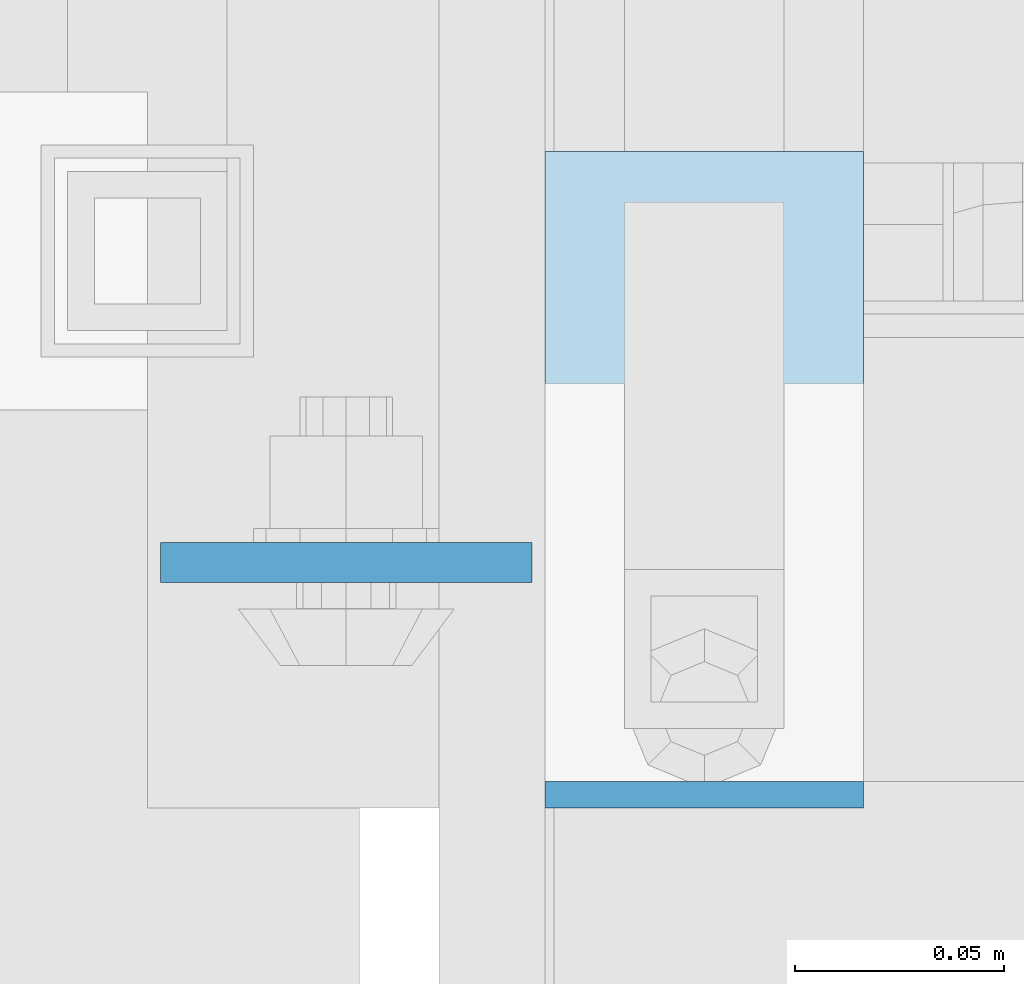
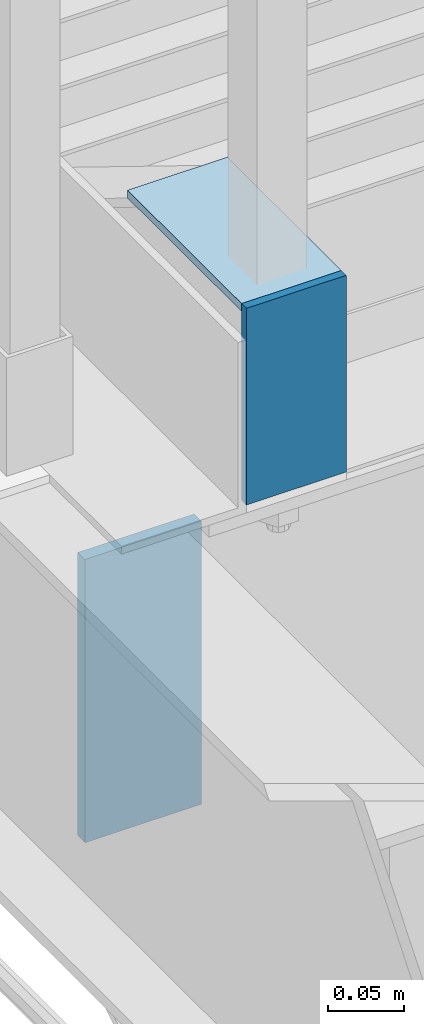
# One storey, part 3104 of 3843: 3 plates, 2 elements without a shape of their own.
"""IFC2X3 building model written with IfcOpenShell, lengths in millimetres."""

from ifc_helpers import new_model, si_unit, frame, origin_with_axes, place, context, subcontext, project, spatial, faceted_brep, material, type_object, element, aggregate, save


model = new_model("IFC2X3")

# Units and contexts
model_context = context("Model", 3, precision=1e-05, world=origin_with_axes())
body_context = subcontext(model_context, "Body", "Model", "MODEL_VIEW")
ifc_project = project(units=[si_unit("LENGTHUNIT", "METRE", prefix="MILLI"), si_unit("AREAUNIT", "SQUARE_METRE"), si_unit("VOLUMEUNIT", "CUBIC_METRE"), si_unit("MASSUNIT", "GRAM", prefix="KILO"), si_unit("TIMEUNIT", "SECOND"), si_unit("PLANEANGLEUNIT", "RADIAN"), si_unit("SOLIDANGLEUNIT", "STERADIAN"), si_unit("THERMODYNAMICTEMPERATUREUNIT", "DEGREE_CELSIUS"), si_unit("LUMINOUSINTENSITYUNIT", "LUMEN")], contexts=[model_context])

# Site, building, storey
site_placement = place(None, origin_with_axes())
site = spatial("IfcSite", under=ifc_project, at=site_placement, CompositionType="ELEMENT")
building_placement = place(site_placement, origin_with_axes())
building = spatial("IfcBuilding", under=site, at=building_placement, Name="Undefined", CompositionType="ELEMENT")
storey_placement = place(building_placement, origin_with_axes())
storey = spatial("IfcBuildingStorey", under=building, at=storey_placement, Name="Undefined", CompositionType="ELEMENT", Elevation=0.0)

# Assembly, plates
assembly_1_placement = place(storey_placement, origin_with_axes())
assembly_1 = element("IfcElementAssembly", 1, at=assembly_1_placement, inside=storey, Name="STAIR", AssemblyPlace="NOTDEFINED", PredefinedType="RIGID_FRAME")
ifc_material_1 = material(Name="STEEL/A36")
plate_type_1 = type_object("IfcPlateType", PredefinedType="NOTDEFINED")
plate_1_placement = place(assembly_1_placement, frame((53162.2000000098, 18824.5749972574, 34975.7999969244), z_axis=(-1.0, 0.0, 0.0), x_axis=(0.0, 0.0, -1.0)))
plate_1 = element("IfcPlate", 2, at=plate_1_placement, type_object=plate_type_1, material=ifc_material_1, Name="PLATE", context=body_context, shape_type="Brep", body=[
    faceted_brep([(0.0, -3.17499999999927, 0.0), (0.0, -3.17499999999927, 76.1999969482422), (0.0, 3.17499999999927, 76.1999969482422), (0.0, 3.17499999999927, 0.0), (158.749994272071, -3.17500000000291, 76.199999999968), (158.749994272071, 3.17500000000291, 76.199999999968), (158.749996174287, -3.17500000000291, -3.63797880709171e-11), (158.749996174287, 3.17500000000291, -3.63797880709171e-11)], [[[0, 1, 2, 3]], [[1, 4, 5, 2]], [[4, 6, 7, 5]], [[6, 0, 3, 7]], [[5, 7, 3, 2]], [[6, 4, 1, 0]]]),
])
plate_2_placement = place(assembly_1_placement, frame((53162.1999999999, 18978.6080188243, 34972.6249969244), z_axis=(0.0, -1.0, 0.0), x_axis=(-1.0, 0.0, 0.0)))
plate_2 = element("IfcPlate", 3, at=plate_2_placement, type_object=plate_type_1, material=ifc_material_1, Name="PLATE", context=body_context, shape_type="Brep", body=[
    faceted_brep([(0.0, -3.17499999999927, 0.0), (-9.88075044006109e-09, -3.17500000000291, 150.858021566859), (-9.88075044006109e-09, 3.17500000000291, 150.858021566859), (0.0, 3.17499999999927, 0.0), (76.1999999901309, -3.17500000000291, 150.85802157185), (76.1999999901309, 3.17500000000291, 150.85802157185), (76.1999999999971, -3.17499999999927, 0.0), (76.1999999999971, 3.17499999999927, 0.0)], [[[0, 1, 2, 3]], [[1, 4, 5, 2]], [[4, 6, 7, 5]], [[6, 0, 3, 7]], [[5, 7, 3, 2]], [[6, 4, 1, 0]]]),
])
aggregate(assembly_1, [plate_1, plate_2])

# Assembly, plate
assembly_2_placement = place(storey_placement, origin_with_axes())
assembly_2 = element("IfcElementAssembly", 4, at=assembly_2_placement, inside=storey, Name="BEAM", AssemblyPlace="NOTDEFINED", PredefinedType="RIGID_FRAME")
ifc_material_2 = material(Name="STEEL/A572-50")
plate_type_2 = type_object("IfcPlateType", PredefinedType="NOTDEFINED")
plate_3_placement = place(assembly_2_placement, frame((52993.925, 18880.1375, 34772.6), z_axis=(1.0, 0.0, 0.0), x_axis=(0.0, 0.0, -1.0)))
plate_3 = element("IfcPlate", 5, at=plate_3_placement, type_object=plate_type_2, material=ifc_material_2, Name="PLATE", context=body_context, shape_type="Brep", body=[
    faceted_brep([(0.0, -4.76249999999709, 0.0), (0.0, -4.76249999999709, 88.9000015258789), (0.0, 4.76249999999709, 88.9000015258789), (0.0, 4.76249999999709, 0.0), (228.600006102781, -4.7625000004191, 88.9000015257589), (228.600006102781, 4.76249999954598, 88.9000015257443), (228.600006103079, -4.7625000004482, 7.27595761418343e-12), (228.600006103079, 4.76249999954598, -7.27595761418343e-12)], [[[0, 1, 2, 3]], [[1, 4, 5, 2]], [[4, 6, 7, 5]], [[6, 0, 3, 7]], [[5, 7, 3, 2]], [[6, 4, 1, 0]]]),
])
aggregate(assembly_2, [plate_3])

save(model, "model.ifc")
